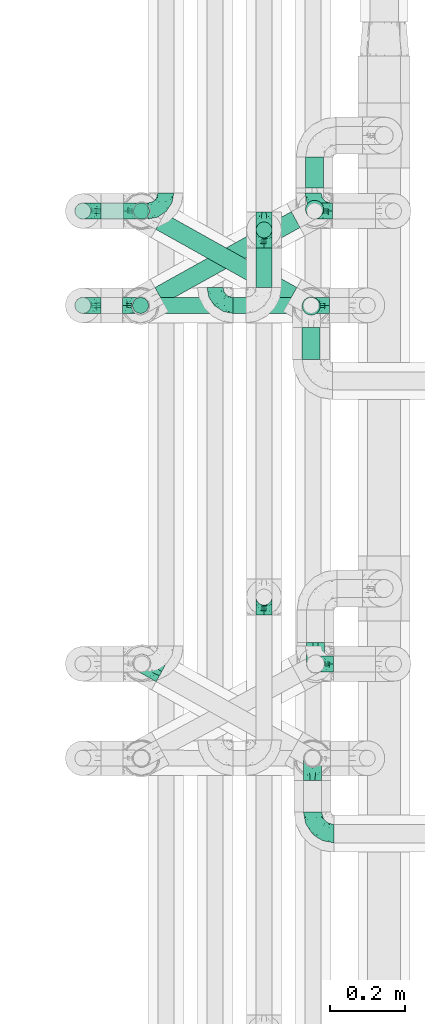
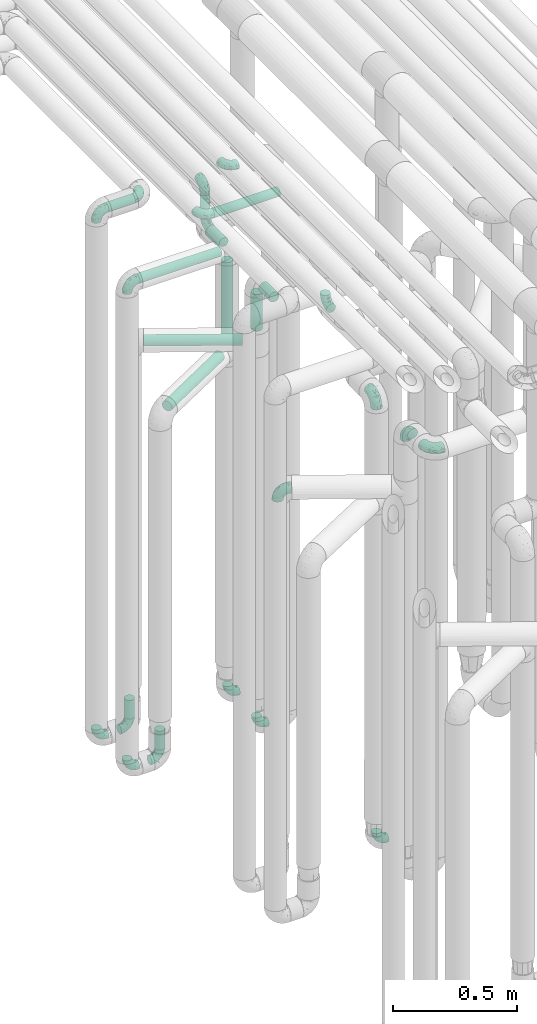
# One storey, part 600 of 824: 19 flow fittings, 13 flow segments.
"""IFC2X3 building model written with IfcOpenShell, lengths in millimetres."""

from ifc_helpers import new_model, entity, si_unit, converted_unit, derived_unit, direction, frame, origin, origin_2d_with_axis, place, context, subcontext, project, spatial, circle, extrude, faceted_brep, source, transform, mapped, material, type_object, type_shapes, element, save


model = new_model("IFC2X3")

# Units and contexts
model_context = context("Model", 3, precision=0.01, world=origin(), true_north=direction((6.12303176911189e-17, 1.0)))
body_context = subcontext(model_context, "Body", "Model", "MODEL_VIEW")
ifc_project = project(units=[si_unit("LENGTHUNIT", "METRE", prefix="MILLI"), si_unit("AREAUNIT", "SQUARE_METRE"), si_unit("VOLUMEUNIT", "CUBIC_METRE"), converted_unit("PLANEANGLEUNIT", "DEGREE", entity("IfcRatioMeasure", 0.0174532925199433), si_unit("PLANEANGLEUNIT", "RADIAN"), dimensions=[0, 0, 0, 0, 0, 0, 0]), si_unit("MASSUNIT", "GRAM", prefix="KILO"), derived_unit("MASSDENSITYUNIT", [(si_unit("MASSUNIT", "GRAM", prefix="KILO"), 1), (si_unit("LENGTHUNIT", "METRE"), -3)]), derived_unit("MOMENTOFINERTIAUNIT", [(si_unit("LENGTHUNIT", "METRE"), 4)]), si_unit("TIMEUNIT", "SECOND"), si_unit("FREQUENCYUNIT", "HERTZ"), si_unit("THERMODYNAMICTEMPERATUREUNIT", "DEGREE_CELSIUS"), derived_unit("THERMALTRANSMITTANCEUNIT", [(si_unit("MASSUNIT", "GRAM", prefix="KILO"), 1), (si_unit("THERMODYNAMICTEMPERATUREUNIT", "KELVIN"), -1), (si_unit("TIMEUNIT", "SECOND"), -3)]), derived_unit("VOLUMETRICFLOWRATEUNIT", [(si_unit("LENGTHUNIT", "METRE"), 3), (si_unit("TIMEUNIT", "SECOND"), -1)]), derived_unit("MASSFLOWRATEUNIT", [(si_unit("MASSUNIT", "GRAM", prefix="KILO"), 1), (si_unit("TIMEUNIT", "SECOND"), -1)]), derived_unit("ROTATIONALFREQUENCYUNIT", [(si_unit("TIMEUNIT", "SECOND"), -1)]), si_unit("ELECTRICCURRENTUNIT", "AMPERE"), si_unit("ELECTRICVOLTAGEUNIT", "VOLT"), si_unit("POWERUNIT", "WATT"), si_unit("FORCEUNIT", "NEWTON", prefix="KILO"), si_unit("ILLUMINANCEUNIT", "LUX"), si_unit("LUMINOUSFLUXUNIT", "LUMEN"), si_unit("LUMINOUSINTENSITYUNIT", "CANDELA"), derived_unit("USERDEFINED", [(si_unit("MASSUNIT", "GRAM", prefix="KILO"), -1), (si_unit("LENGTHUNIT", "METRE"), -2), (si_unit("TIMEUNIT", "SECOND"), 3), (si_unit("LUMINOUSFLUXUNIT", "LUMEN"), 1)]), derived_unit("LINEARVELOCITYUNIT", [(si_unit("LENGTHUNIT", "METRE"), 1), (si_unit("TIMEUNIT", "SECOND"), -1)]), si_unit("PRESSUREUNIT", "PASCAL"), derived_unit("USERDEFINED", [(si_unit("LENGTHUNIT", "METRE"), -2), (si_unit("MASSUNIT", "GRAM", prefix="KILO"), 1), (si_unit("TIMEUNIT", "SECOND"), -2)]), derived_unit("LINEARFORCEUNIT", [(si_unit("MASSUNIT", "GRAM", prefix="KILO"), 1), (si_unit("LENGTHUNIT", "METRE"), 1), (si_unit("TIMEUNIT", "SECOND"), -2), (si_unit("LENGTHUNIT", "METRE"), -1)]), derived_unit("PLANARFORCEUNIT", [(si_unit("MASSUNIT", "GRAM", prefix="KILO"), 1), (si_unit("LENGTHUNIT", "METRE"), 1), (si_unit("TIMEUNIT", "SECOND"), -2), (si_unit("LENGTHUNIT", "METRE"), -2)])], contexts=[model_context])

# Site, building, storey
site_placement = place(None, origin())
site = spatial("IfcSite", under=ifc_project, at=site_placement, CompositionType="ELEMENT")
building_placement = place(site_placement, origin())
building = spatial("IfcBuilding", under=site, at=building_placement, CompositionType="ELEMENT")
storey_placement = place(building_placement, frame((0.0, 0.0, 28200.0)))
storey = spatial("IfcBuildingStorey", under=building, at=storey_placement, CompositionType="ELEMENT", Elevation=28200.0)

# Flow segments
pipe_segment_type = type_object("IfcPipeSegmentType", PredefinedType="NOTDEFINED")
flow_segment_1_placement = place(storey_placement, frame((35168.03, 12983.46, 2977.25)))
element("IfcFlowSegment", 1, at=flow_segment_1_placement, inside=storey, type_object=pipe_segment_type, context=body_context, shape_type="SweptSolid", body=[
    extrude(circle(Radius=21.15, at=origin_2d_with_axis()), frame((0.0, 22.75, 22.75), z_axis=(1.0, 0.0, 0.0), x_axis=(0.0, 1.0, 0.0)), (0.0, 0.0, 1.0), 124.000000000015),
])
for number, where in (
    (2, (35252.6, 12983.46, 448.0)),
    (3, (35250.16, 12733.46, 448.0)),
):
    element("IfcFlowSegment", number, at=place(storey_placement, frame(where)), inside=storey, type_object=pipe_segment_type, context=body_context, shape_type="SweptSolid", body=[
        extrude(circle(Radius=21.15, at=origin_2d_with_axis()), frame((22.75, 22.75, 0.0), z_axis=(0.0, 0.0, 1.0), x_axis=(-1.0, 0.0, 0.0)), (0.0, 0.0, 1.0), 92.0000000000094),
    ])
flow_segment_2_placement = place(storey_placement, frame((35577.35, 12933.43, 2847.61)))
element("IfcFlowSegment", 4, at=flow_segment_2_placement, inside=storey, type_object=pipe_segment_type, context=body_context, shape_type="SweptSolid", body=[
    extrude(circle(Radius=21.15, at=origin_2d_with_axis()), frame((22.75, 22.75, 0.0)), (0.0, 0.0, 1.0), 104.39114387437),
])
flow_segment_3_placement = place(storey_placement, frame((35577.35, 12804.17, 2776.86)))
element("IfcFlowSegment", 5, at=flow_segment_3_placement, inside=storey, type_object=pipe_segment_type, context=body_context, shape_type="SweptSolid", body=[
    extrude(circle(Radius=21.15, at=origin_2d_with_axis()), frame((22.75, 0.0, 22.75), z_axis=(0.0, 1.0, 0.0), x_axis=(-1.0, 0.0, 0.0)), (0.0, 0.0, 1.0), 104.000000000015),
])
flow_segment_4_placement = place(storey_placement, frame((35168.03, 12733.43, 2776.86)))
element("IfcFlowSegment", 6, at=flow_segment_4_placement, inside=storey, type_object=pipe_segment_type, context=body_context, shape_type="SweptSolid", body=[
    extrude(circle(Radius=21.15, at=origin_2d_with_axis()), frame((0.0, 22.77, 22.75), z_axis=(0.999999997789185, -6.64953413086212e-05, 0.0), x_axis=(-6.64953413086212e-05, -0.999999997789185, 0.0)), (0.0, 0.0, 1.0), 384.054259178842),
])
flow_segment_5_placement = place(storey_placement, frame((35518.03, 12733.42, 2977.25)))
element("IfcFlowSegment", 7, at=flow_segment_5_placement, inside=storey, type_object=pipe_segment_type, context=body_context, shape_type="SweptSolid", body=[
    extrude(circle(Radius=21.15, at=origin_2d_with_axis()), frame((0.0, 22.75, 22.75), z_axis=(1.0, 0.0, 0.0), x_axis=(0.0, -1.0, 0.0)), (0.0, 0.0, 1.0), 307.750000000012),
])
flow_segment_6_placement = place(storey_placement, frame((35708.54, 12985.08, 2157.0)))
element("IfcFlowSegment", 8, at=flow_segment_6_placement, inside=storey, type_object=pipe_segment_type, context=body_context, shape_type="SweptSolid", body=[
    extrude(circle(Radius=24.0, at=origin_2d_with_axis()), frame((25.6, 25.6, 0.0), z_axis=(0.0, 0.0, 1.0), x_axis=(-1.0, 0.0, 0.0)), (0.0, 0.0, 1.0), 385.999999999986),
])
flow_segment_7_placement = place(storey_placement, frame((35699.44, 12728.87, 2362.0)))
element("IfcFlowSegment", 9, at=flow_segment_7_placement, inside=storey, type_object=pipe_segment_type, context=body_context, shape_type="SweptSolid", body=[
    extrude(circle(Radius=24.0, at=origin_2d_with_axis()), frame((25.6, 25.6, 0.0), z_axis=(0.0, 0.0, 1.0), x_axis=(-1.0, 0.0, 0.0)), (0.0, 0.0, 1.0), 180.999999999998),
])
flow_segment_8_placement = place(storey_placement, frame((35311.78, 12760.12, 2279.4)))
element("IfcFlowSegment", 10, at=flow_segment_8_placement, inside=storey, type_object=pipe_segment_type, context=body_context, shape_type="SweptSolid", body=[
    extrude(circle(Radius=24.0, at=origin_2d_with_axis()), frame((13.31, 218.58, 25.6), z_axis=(0.872709832917215, -0.488239231862421, 0.0), x_axis=(-0.488239231862421, -0.872709832917215, 0.0)), (0.0, 0.0, 1.0), 401.518720143664),
])
flow_segment_9_placement = place(storey_placement, frame((35309.45, 12759.99, 2074.4)))
element("IfcFlowSegment", 11, at=flow_segment_9_placement, inside=storey, type_object=pipe_segment_type, context=body_context, shape_type="SweptSolid", body=[
    extrude(circle(Radius=24.0, at=origin_2d_with_axis()), frame((13.26, 22.57, 25.6), z_axis=(0.873900740639491, 0.486104408033654, 0.0), x_axis=(0.486104408033654, -0.873900740639491, 0.0)), (0.0, 0.0, 1.0), 413.435297220392),
])
flow_segment_10_placement = place(storey_placement, frame((35708.65, 13067.49, 2574.4)))
element("IfcFlowSegment", 12, at=flow_segment_10_placement, inside=storey, type_object=pipe_segment_type, context=body_context, shape_type="SweptSolid", body=[
    extrude(circle(Radius=24.0, at=origin_2d_with_axis()), frame((25.6, 0.0, 25.6), z_axis=(0.0, 1.0, 0.0), x_axis=(1.0, 0.0, 0.0)), (0.0, 0.0, 1.0), 81.5902938725285),
])
flow_segment_11_placement = place(storey_placement, frame((35699.44, 12613.08, 2574.4)))
element("IfcFlowSegment", 13, at=flow_segment_11_placement, inside=storey, type_object=pipe_segment_type, context=body_context, shape_type="SweptSolid", body=[
    extrude(circle(Radius=24.0, at=origin_2d_with_axis()), frame((25.6, 0.0, 25.6), z_axis=(0.0, 1.0, 0.0), x_axis=(-1.0, 0.0, 0.0)), (0.0, 0.0, 1.0), 84.3822522691478),
])

# Flow fittings
ifc_material = material()
pipe_fitting_type_1 = type_object("IfcPipeFittingType", PredefinedType="NOTDEFINED", material=ifc_material)
shared_shape_1 = source(origin(), body_context, "Body", "Brep", [
    faceted_brep([(-57.0, 12.07, -20.91), (-57.0, 6.25, -23.33), (-57.0, 0.0, -24.15), (-57.0, -6.25, -23.33), (-57.0, -12.08, -20.91), (-57.0, -17.08, -17.08), (-57.0, -20.91, -12.08), (-57.0, -23.33, -6.25), (-57.0, -24.15, 0.0), (-57.0, -23.33, 6.25), (-57.0, -20.91, 12.07), (-57.0, -17.08, 17.08), (-57.0, -12.08, 20.91), (-57.0, -6.25, 23.33), (-57.0, 0.0, 24.15), (-57.0, 6.25, 23.33), (-57.0, 12.07, 20.91), (-57.0, 17.08, 17.08), (-57.0, 20.91, 12.07), (-57.0, 23.33, 6.25), (-57.0, 24.15, 0.0), (-57.0, 23.33, -6.25), (-57.0, 20.91, -12.08), (-57.0, 17.08, -17.08), (0.0, 57.0, -24.15), (-6.25, 57.0, -23.33), (-12.07, 57.0, -20.91), (-17.08, 57.0, -17.08), (-20.91, 57.0, -12.08), (-23.33, 57.0, -6.25), (-24.15, 57.0, 0.0), (-23.33, 57.0, 6.25), (-20.91, 57.0, 12.07), (-17.08, 57.0, 17.08), (-12.07, 57.0, 20.91), (-6.25, 57.0, 23.33), (0.0, 57.0, 24.15), (6.25, 57.0, 23.33), (12.08, 57.0, 20.91), (17.08, 57.0, 17.08), (20.91, 57.0, 12.07), (23.33, 57.0, 6.25), (24.15, 57.0, 0.0), (23.33, 57.0, -6.25), (20.91, 57.0, -12.08), (17.08, 57.0, -17.08), (12.08, 57.0, -20.91), (6.25, 57.0, -23.33), (14.9, 21.14, 6.17), (13.61, 24.64, 12.48), (6.23, 8.95, 8.98), (-41.47, -21.06, 0.0), (-41.92, -18.38, 13.72), (-24.64, -13.61, 12.48), (-37.37, -13.24, 18.15), (-6.8, -4.93, 8.18), (-21.76, -15.19, 6.22), (-12.78, -9.18, 0.0), (-37.73, -20.51, 7.75), (-7.38, 7.38, 20.24), (-23.37, -4.26, 20.42), (-11.9, -3.19, 15.86), (-42.14, -8.7, 21.82), (13.24, 37.37, 18.15), (9.33, 23.53, 16.85), (4.26, 23.37, 20.42), (2.77, 10.92, 15.55), (-29.46, 0.91, 23.52), (-44.13, 20.56, 15.69), (-39.25, 26.33, 10.88), (-49.02, 22.92, 9.96), (-34.58, 23.87, 17.15), (-15.8, 6.8, 22.81), (-8.67, 20.47, 23.88), (-18.12, 12.9, 24.08), (-48.29, 14.92, 19.65), (-44.06, -2.85, 23.78), (-9.23, 48.95, 22.58), (-3.78, 42.74, 24.07), (-40.34, 4.26, 24.09), (-44.02, 26.14, 5.46), (-44.04, 9.88, 22.74), (-4.95, 16.87, 22.52), (-2.75, 1.43, 12.5), (-25.48, 40.98, 10.71), (20.51, 37.73, 7.75), (18.38, 41.92, 13.72), (8.7, 42.14, 21.82), (-25.95, -17.97, 0.0), (2.85, 44.06, 23.78), (21.06, 41.47, 0.0), (17.97, 25.95, 0.0), (-24.04, -9.27, 17.13), (-33.26, 33.26, 5.86), (-28.55, 40.57, 0.0), (-40.57, 28.55, 0.0), (-25.29, 47.19, 4.06), (-27.01, 31.1, 16.77), (-15.7, 43.95, 19.9), (-20.27, 45.22, 15.61), (-30.53, 31.98, 12.64), (-11.28, 38.33, 22.92), (-9.97, 27.88, 24.09), (-20.15, 30.26, 21.25), (-31.25, 11.75, 23.64), (-28.75, 7.23, 24.15), (-29.53, 18.06, 22.27), (-28.44, 24.21, 20.02), (-37.55, 17.7, 20.26), (-15.88, 29.25, 22.99), (-20.82, 20.82, 23.44), (-0.91, 29.46, 23.52), (-13.5, -7.67, 12.04), (1.49, 1.56, 5.16), (8.86, 10.35, 4.59), (0.38, -0.38, 0.0), (9.18, 12.78, 0.0), (-37.37, -13.24, -18.15), (8.86, 10.35, -4.59), (-45.22, 20.27, -15.61), (-43.95, 15.7, -19.9), (-38.33, 11.28, -22.92), (-48.95, 9.23, -22.58), (-47.19, 25.29, -4.06), (-33.26, 33.26, -5.86), (18.38, 41.92, -13.72), (-30.26, 20.15, -21.25), (2.85, 44.06, -23.78), (-4.26, 40.34, -24.09), (-40.98, 25.48, -10.71), (-41.92, -18.38, -13.72), (9.25, 23.5, -16.92), (4.26, 23.37, -20.42), (13.24, 37.37, -18.15), (-37.73, -20.51, -7.75), (-11.75, 31.25, -23.64), (-7.23, 28.75, -24.15), (-12.9, 18.12, -24.08), (8.7, 42.14, -21.82), (-44.06, -2.85, -23.78), (-6.8, 15.8, -22.81), (-20.47, 8.67, -23.88), (-24.64, -13.61, -12.48), (-42.74, 3.78, -24.07), (-18.06, 29.53, -22.27), (-24.21, 28.44, -20.02), (-27.88, 9.97, -24.09), (-31.1, 27.01, -16.77), (-26.14, 44.02, -5.46), (14.9, 21.14, -6.17), (20.51, 37.73, -7.75), (-9.88, 44.04, -22.74), (-20.56, 44.13, -15.69), (-21.76, -15.19, -6.22), (-13.5, -7.67, -12.04), (-24.14, -9.76, -16.74), (-11.9, -3.19, -15.86), (-14.92, 48.29, -19.65), (-23.37, -4.26, -20.42), (-0.91, 29.46, -23.52), (-26.33, 39.25, -10.88), (-23.87, 34.58, -17.15), (-42.14, -8.7, -21.82), (-22.92, 49.02, -9.96), (13.61, 24.64, -12.48), (-31.98, 30.53, -12.64), (-16.87, 4.95, -22.52), (-17.7, 37.55, -20.26), (-29.25, 15.88, -22.99), (-20.82, 20.82, -23.44), (-29.46, 0.91, -23.52), (-7.38, 7.38, -20.24), (2.77, 10.92, -15.55), (6.23, 8.95, -8.98), (-6.8, -4.93, -8.18), (-2.81, 1.41, -12.54), (1.49, 1.56, -5.16)], [[[0, 1, 2, 3, 4, 5, 6, 7, 8, 9, 10, 11, 12, 13, 14, 15, 16, 17, 18, 19, 20, 21, 22, 23]], [[24, 25, 26, 27, 28, 29, 30, 31, 32, 33, 34, 35, 36, 37, 38, 39, 40, 41, 42, 43, 44, 45, 46, 47]], [[48, 49, 50]], [[9, 8, 51]], [[52, 53, 54]], [[55, 56, 57]], [[10, 58, 52]], [[9, 58, 10]], [[59, 60, 61]], [[54, 12, 11]], [[54, 62, 12]], [[63, 39, 38]], [[64, 65, 66]], [[62, 60, 67]], [[68, 69, 70]], [[71, 69, 68]], [[72, 73, 74]], [[16, 75, 17]], [[13, 76, 14]], [[35, 77, 78]], [[14, 79, 15]], [[17, 68, 18]], [[14, 76, 79]], [[20, 19, 80]], [[70, 19, 18]], [[81, 15, 79]], [[15, 81, 16]], [[73, 72, 82]], [[66, 83, 50]], [[32, 31, 84]], [[85, 86, 49]], [[63, 87, 65]], [[56, 58, 88]], [[36, 89, 37]], [[85, 41, 40]], [[36, 35, 78]], [[90, 41, 85]], [[40, 39, 86]], [[12, 62, 13]], [[86, 85, 40]], [[48, 85, 49]], [[85, 91, 90]], [[87, 38, 37]], [[92, 60, 54]], [[80, 69, 93]], [[93, 94, 95]], [[10, 52, 11]], [[94, 96, 30]], [[97, 98, 99]], [[80, 93, 95]], [[100, 97, 84]], [[99, 98, 33]], [[101, 102, 78]], [[103, 101, 98]], [[96, 31, 30]], [[77, 98, 101]], [[77, 35, 34]], [[34, 33, 98]], [[9, 51, 58]], [[87, 63, 38]], [[104, 105, 74]], [[106, 103, 107]], [[106, 81, 104]], [[75, 68, 17]], [[108, 107, 71]], [[33, 32, 99]], [[109, 103, 110]], [[101, 109, 102]], [[89, 78, 111]], [[53, 52, 58]], [[54, 11, 52]], [[60, 62, 54]], [[88, 58, 51]], [[76, 62, 67]], [[53, 112, 92]], [[60, 59, 72]], [[39, 63, 86]], [[49, 86, 63]], [[89, 87, 37]], [[42, 41, 90]], [[111, 82, 65]], [[111, 65, 87]], [[65, 59, 66]], [[104, 81, 79]], [[75, 81, 108]], [[32, 84, 99]], [[97, 99, 84]], [[98, 97, 103]], [[106, 107, 108]], [[74, 102, 110]], [[111, 78, 102]], [[74, 110, 104]], [[74, 67, 72]], [[61, 92, 112]], [[66, 59, 61]], [[56, 53, 58]], [[66, 50, 49]], [[61, 112, 83]], [[66, 49, 64]], [[78, 89, 36]], [[87, 89, 111]], [[62, 76, 13]], [[79, 76, 67]], [[100, 93, 69]], [[96, 93, 84]], [[55, 113, 50]], [[113, 114, 50]], [[104, 79, 105]], [[106, 104, 110]], [[20, 80, 95]], [[85, 48, 91]], [[115, 114, 113]], [[116, 91, 48]], [[70, 80, 19]], [[93, 96, 94]], [[84, 31, 96]], [[103, 106, 110]], [[81, 106, 108]], [[103, 97, 107]], [[71, 107, 97]], [[71, 97, 100]], [[108, 71, 68]], [[79, 67, 105]], [[67, 74, 105]], [[115, 113, 57]], [[112, 56, 55]], [[56, 88, 57]], [[60, 72, 67]], [[82, 72, 59]], [[65, 82, 59]], [[82, 111, 73]], [[111, 102, 73]], [[102, 74, 73]], [[81, 75, 16]], [[68, 75, 108]], [[68, 70, 18]], [[80, 70, 69]], [[98, 77, 34]], [[78, 77, 101]], [[93, 100, 84]], [[71, 100, 69]], [[102, 109, 110]], [[101, 103, 109]], [[53, 92, 54]], [[61, 60, 92]], [[56, 112, 53]], [[83, 112, 55]], [[50, 83, 55]], [[61, 83, 66]], [[49, 63, 64]], [[65, 64, 63]], [[57, 113, 55]], [[114, 115, 116]], [[116, 48, 114]], [[48, 50, 114]], [[117, 5, 4]], [[116, 115, 118]], [[119, 120, 23]], [[121, 122, 120]], [[95, 123, 20]], [[0, 23, 120]], [[124, 95, 94]], [[125, 45, 44]], [[121, 120, 126]], [[24, 127, 128]], [[22, 21, 129]], [[0, 122, 1]], [[5, 117, 130]], [[131, 132, 133]], [[134, 88, 51]], [[135, 136, 137]], [[6, 5, 130]], [[46, 138, 47]], [[139, 3, 2]], [[140, 141, 137]], [[6, 134, 7]], [[134, 130, 142]], [[143, 2, 1]], [[144, 126, 145]], [[121, 146, 143]], [[147, 120, 119]], [[94, 148, 124]], [[149, 150, 91]], [[30, 29, 148]], [[151, 25, 128]], [[27, 152, 28]], [[134, 153, 88]], [[154, 155, 156]], [[27, 26, 157]], [[151, 26, 25]], [[155, 158, 156]], [[24, 47, 127]], [[1, 122, 143]], [[138, 132, 159]], [[160, 152, 161]], [[24, 128, 25]], [[46, 133, 138]], [[162, 117, 4]], [[148, 160, 124]], [[152, 160, 163]], [[154, 142, 155]], [[45, 125, 133]], [[133, 46, 45]], [[125, 164, 133]], [[51, 7, 134]], [[42, 90, 43]], [[165, 147, 129]], [[153, 134, 142]], [[43, 150, 44]], [[162, 4, 3]], [[141, 140, 166]], [[117, 162, 158]], [[163, 29, 28]], [[43, 90, 150]], [[123, 21, 20]], [[144, 151, 135]], [[157, 152, 27]], [[167, 145, 161]], [[23, 22, 119]], [[168, 126, 169]], [[121, 168, 146]], [[139, 143, 170]], [[142, 130, 117]], [[8, 7, 51]], [[134, 6, 130]], [[139, 162, 3]], [[170, 166, 158]], [[170, 158, 162]], [[158, 171, 156]], [[44, 150, 125]], [[91, 150, 90]], [[164, 125, 150]], [[132, 138, 133]], [[127, 138, 159]], [[131, 164, 172]], [[132, 171, 140]], [[135, 151, 128]], [[157, 151, 167]], [[22, 129, 119]], [[147, 119, 129]], [[120, 147, 126]], [[144, 145, 167]], [[137, 146, 169]], [[170, 143, 146]], [[137, 169, 135]], [[137, 159, 140]], [[171, 172, 156]], [[173, 174, 175]], [[156, 175, 154]], [[174, 57, 153]], [[132, 172, 171]], [[172, 164, 173]], [[143, 139, 2]], [[162, 139, 170]], [[138, 127, 47]], [[128, 127, 159]], [[165, 124, 160]], [[123, 124, 129]], [[149, 173, 164]], [[176, 174, 173]], [[135, 128, 136]], [[144, 135, 169]], [[150, 149, 164]], [[176, 118, 115]], [[149, 91, 116]], [[30, 148, 94]], [[163, 148, 29]], [[124, 123, 95]], [[129, 21, 123]], [[126, 144, 169]], [[151, 144, 167]], [[126, 147, 145]], [[161, 145, 147]], [[161, 147, 165]], [[167, 161, 152]], [[128, 159, 136]], [[159, 137, 136]], [[154, 153, 142]], [[132, 140, 159]], [[174, 176, 57]], [[57, 88, 153]], [[166, 140, 171]], [[158, 166, 171]], [[166, 170, 141]], [[170, 146, 141]], [[146, 137, 141]], [[151, 157, 26]], [[152, 157, 167]], [[152, 163, 28]], [[148, 163, 160]], [[120, 122, 0]], [[143, 122, 121]], [[124, 165, 129]], [[161, 165, 160]], [[146, 168, 169]], [[121, 126, 168]], [[142, 117, 155]], [[158, 155, 117]], [[175, 156, 172]], [[153, 154, 174]], [[173, 175, 172]], [[174, 154, 175]], [[164, 131, 133]], [[172, 132, 131]], [[176, 173, 118]], [[57, 176, 115]], [[173, 149, 118]], [[149, 116, 118]]]),
])
type_shapes(pipe_fitting_type_1, [shared_shape_1])
for number, where, z_axis, x_axis in (
    (14, (35736.85, 11805.67, 2600.0), (-1.0, 0.0, 0.0), (0.0, 0.0, 1.0)),
    (15, (35728.78, 11554.46, 2600.0), (1.0, 0.0, 0.0), (0.0, 0.0, 1.0)),
    (16, (35728.78, 11356.08, 2600.0), (0.0, 0.0, 1.0), (0.0, -1.0, 0.0)),
    (17, (35276.24, 11808.13, 2305.0), (-0.488239203591698, -0.872709848733326, 0.0), (-0.872709848733326, 0.488239203591698, 0.0)),
):
    element("IfcFlowFitting", number, at=place(storey_placement, frame(where, z_axis=z_axis, x_axis=x_axis)), inside=storey, type_object=pipe_fitting_type_1, material=ifc_material, context=body_context, shape_type="MappedRepresentation", body=[
        mapped(shared_shape_1, transform((0.0, 0.0, 0.0), scale=1.0)),
    ])
pipe_fitting_type_2 = type_object("IfcPipeFittingType", PredefinedType="NOTDEFINED", material=ifc_material)
shared_shape_2 = source(origin(), body_context, "Body", "Brep", [
    faceted_brep([(-48.0, 10.6, -18.36), (-48.0, 5.49, -20.48), (-48.0, 0.0, -21.2), (-48.0, -5.49, -20.48), (-48.0, -10.6, -18.36), (-48.0, -14.99, -14.99), (-48.0, -18.36, -10.6), (-48.0, -20.48, -5.49), (-48.0, -21.2, 0.0), (-48.0, -20.48, 5.49), (-48.0, -18.36, 10.6), (-48.0, -14.99, 14.99), (-48.0, -10.6, 18.36), (-48.0, -5.49, 20.48), (-48.0, 0.0, 21.2), (-48.0, 5.49, 20.48), (-48.0, 10.6, 18.36), (-48.0, 14.99, 14.99), (-48.0, 18.36, 10.6), (-48.0, 20.48, 5.49), (-48.0, 21.2, 0.0), (-48.0, 20.48, -5.49), (-48.0, 18.36, -10.6), (-48.0, 14.99, -14.99), (0.0, 48.0, -21.2), (-5.49, 48.0, -20.48), (-10.6, 48.0, -18.36), (-14.99, 48.0, -14.99), (-18.36, 48.0, -10.6), (-20.48, 48.0, -5.49), (-21.2, 48.0, 0.0), (-20.48, 48.0, 5.49), (-18.36, 48.0, 10.6), (-14.99, 48.0, 14.99), (-10.6, 48.0, 18.36), (-5.49, 48.0, 20.48), (0.0, 48.0, 21.2), (5.49, 48.0, 20.48), (10.6, 48.0, 18.36), (14.99, 48.0, 14.99), (18.36, 48.0, 10.6), (20.48, 48.0, 5.49), (21.2, 48.0, 0.0), (20.48, 48.0, -5.49), (18.36, 48.0, -10.6), (14.99, 48.0, -14.99), (10.6, 48.0, -18.36), (5.49, 48.0, -20.48), (-35.25, -16.22, 12.01), (-34.76, -18.57, 0.0), (-20.87, -12.37, 10.9), (-31.49, -11.78, 15.9), (-37.0, -2.58, 20.86), (-33.89, 3.62, 21.15), (-31.81, -18.14, 6.76), (-5.78, 5.78, 17.67), (-19.42, -4.1, 17.86), (-9.6, -3.39, 13.73), (-35.44, -7.73, 19.13), (11.78, 31.49, 15.9), (-5.93, -5.46, 6.95), (-18.45, -13.78, 5.46), (-10.29, -8.43, 0.0), (-24.6, 0.55, 20.62), (-37.28, 17.94, 13.81), (-33.38, 22.85, 9.59), (-41.46, 20.06, 8.75), (-29.51, 20.45, 15.16), (-15.04, 10.79, 21.13), (-7.08, 16.98, 20.93), (-8.39, 23.51, 21.15), (-40.86, 13.03, 17.26), (-8.05, 41.26, 19.83), (-3.21, 35.97, 21.14), (8.53, 19.66, 14.74), (4.1, 19.42, 17.86), (-37.72, 22.66, 4.78), (-37.07, 8.58, 19.98), (-13.0, 5.43, 19.97), (-3.78, 13.93, 19.7), (3.02, 8.69, 13.43), (-2.27, -0.05, 10.65), (6.22, 6.99, 7.09), (-22.25, 34.6, 9.45), (18.14, 31.81, 6.76), (16.22, 35.25, 12.01), (12.37, 20.87, 10.9), (7.73, 35.44, 19.13), (-21.52, -15.93, 0.0), (2.58, 37.0, 20.86), (18.57, 34.76, 0.0), (13.78, 18.45, 5.46), (15.93, 21.52, 0.0), (-20.03, -8.54, 14.9), (-28.6, 28.6, 5.16), (-24.79, 34.6, 0.0), (-34.6, 24.79, 0.0), (-22.81, 37.41, 4.68), (-23.36, 26.33, 14.79), (-13.68, 37.05, 17.49), (-17.72, 38.12, 13.73), (-26.25, 27.3, 11.24), (-9.71, 32.34, 20.14), (-17.26, 25.6, 18.71), (-26.33, 9.99, 20.77), (-24.06, 6.05, 21.2), (-25.02, 15.46, 19.56), (-24.3, 20.72, 17.57), (-31.95, 15.23, 17.8), (-13.53, 24.7, 20.21), (-17.6, 17.6, 20.6), (-0.55, 24.6, 20.62), (-11.41, -7.48, 10.43), (0.93, -0.93, 0.0), (8.43, 10.29, 0.0), (-11.41, -7.48, -10.43), (-20.1, -8.84, -14.66), (-9.6, -3.39, -13.73), (7.73, 35.44, -19.13), (4.1, 19.42, -17.86), (-0.55, 24.6, -20.62), (-38.12, 17.72, -13.73), (-37.05, 13.68, -17.49), (-32.34, 9.71, -20.14), (-41.26, 8.05, -19.83), (-37.41, 22.81, -4.68), (-23.51, 8.39, -21.15), (-35.97, 3.21, -21.14), (-28.6, 28.6, -5.16), (-31.81, -18.14, -6.76), (-18.45, -13.78, -5.46), (-25.6, 17.26, -18.71), (-19.42, -4.1, -17.86), (-17.94, 37.28, -13.81), (-22.85, 33.38, -9.59), (-20.06, 41.46, -8.75), (-31.49, -11.78, -15.9), (-35.25, -16.22, -12.01), (8.53, 19.66, -14.74), (11.78, 31.49, -15.9), (-9.99, 26.33, -20.77), (-6.05, 24.06, -21.2), (-10.79, 15.04, -21.13), (-37.0, -2.58, -20.86), (-16.98, 7.08, -20.93), (-5.43, 13.0, -19.97), (-13.93, 3.78, -19.7), (-20.87, -12.37, -10.9), (-26.33, 23.36, -14.79), (-22.66, 37.72, -4.78), (13.78, 18.45, -5.46), (18.14, 31.81, -6.76), (-15.46, 25.02, -19.56), (-20.72, 24.3, -17.57), (16.22, 35.25, -12.01), (-13.03, 40.86, -17.26), (-8.58, 37.07, -19.98), (2.58, 37.0, -20.86), (-3.62, 33.89, -21.15), (-34.6, 22.25, -9.45), (6.22, 6.99, -7.09), (-20.45, 29.51, -15.16), (-35.44, -7.73, -19.13), (12.37, 20.87, -10.9), (-27.3, 26.25, -11.24), (-15.23, 31.95, -17.8), (-24.7, 13.53, -20.21), (-24.6, 0.55, -20.62), (-5.78, 5.78, -17.67), (-17.6, 17.6, -20.6), (3.02, 8.69, -13.43), (-5.93, -5.46, -6.95), (-2.27, -0.05, -10.65)], [[[0, 1, 2, 3, 4, 5, 6, 7, 8, 9, 10, 11, 12, 13, 14, 15, 16, 17, 18, 19, 20, 21, 22, 23]], [[24, 25, 26, 27, 28, 29, 30, 31, 32, 33, 34, 35, 36, 37, 38, 39, 40, 41, 42, 43, 44, 45, 46, 47]], [[10, 48, 11]], [[9, 8, 49]], [[48, 50, 51]], [[14, 52, 53]], [[10, 54, 48]], [[9, 54, 10]], [[55, 56, 57]], [[51, 12, 11]], [[51, 58, 12]], [[59, 39, 38]], [[60, 61, 62]], [[58, 56, 63]], [[64, 65, 66]], [[67, 65, 64]], [[68, 69, 70]], [[16, 71, 17]], [[13, 52, 14]], [[35, 72, 73]], [[14, 53, 15]], [[17, 64, 18]], [[74, 59, 75]], [[20, 19, 76]], [[66, 19, 18]], [[77, 15, 53]], [[15, 77, 16]], [[69, 78, 79]], [[80, 81, 82]], [[32, 31, 83]], [[84, 85, 86]], [[59, 87, 75]], [[61, 54, 88]], [[36, 89, 37]], [[84, 41, 40]], [[36, 35, 73]], [[90, 41, 84]], [[40, 39, 85]], [[12, 58, 13]], [[85, 84, 40]], [[91, 84, 86]], [[84, 92, 90]], [[87, 38, 37]], [[93, 56, 51]], [[65, 94, 76]], [[94, 95, 96]], [[84, 91, 92]], [[95, 97, 30]], [[98, 99, 100]], [[76, 94, 96]], [[101, 98, 83]], [[100, 99, 33]], [[102, 70, 73]], [[103, 102, 99]], [[94, 97, 95]], [[72, 99, 102]], [[72, 35, 34]], [[34, 33, 99]], [[9, 49, 54]], [[87, 59, 38]], [[104, 105, 68]], [[106, 103, 107]], [[106, 77, 104]], [[71, 64, 17]], [[108, 107, 67]], [[33, 32, 100]], [[109, 103, 110]], [[102, 109, 70]], [[89, 73, 111]], [[50, 48, 54]], [[51, 11, 48]], [[56, 58, 51]], [[88, 54, 49]], [[52, 58, 63]], [[50, 112, 93]], [[56, 55, 78]], [[39, 59, 85]], [[86, 85, 59]], [[89, 87, 37]], [[42, 41, 90]], [[111, 79, 75]], [[111, 75, 87]], [[75, 55, 80]], [[104, 77, 53]], [[71, 77, 108]], [[32, 83, 100]], [[98, 100, 83]], [[99, 98, 103]], [[106, 107, 108]], [[68, 70, 110]], [[111, 73, 70]], [[68, 110, 104]], [[68, 63, 78]], [[57, 93, 112]], [[80, 55, 57]], [[61, 50, 54]], [[80, 82, 86]], [[81, 57, 112]], [[74, 86, 59]], [[60, 113, 82]], [[82, 114, 91]], [[101, 94, 65]], [[97, 94, 83]], [[73, 89, 36]], [[87, 89, 111]], [[58, 52, 13]], [[53, 52, 63]], [[104, 53, 105]], [[106, 104, 110]], [[20, 76, 96]], [[76, 19, 66]], [[103, 106, 110]], [[77, 106, 108]], [[103, 98, 107]], [[67, 107, 98]], [[67, 98, 101]], [[108, 67, 64]], [[53, 63, 105]], [[63, 68, 105]], [[83, 31, 97]], [[30, 97, 31]], [[62, 113, 60]], [[112, 61, 60]], [[61, 88, 62]], [[86, 82, 91]], [[56, 78, 63]], [[114, 82, 113]], [[114, 92, 91]], [[79, 78, 55]], [[75, 79, 55]], [[69, 79, 111]], [[70, 69, 111]], [[78, 69, 68]], [[77, 71, 16]], [[64, 71, 108]], [[64, 66, 18]], [[76, 66, 65]], [[99, 72, 34]], [[73, 72, 102]], [[94, 101, 83]], [[67, 101, 65]], [[75, 80, 74]], [[80, 86, 74]], [[70, 109, 110]], [[102, 103, 109]], [[50, 93, 51]], [[57, 56, 93]], [[61, 112, 50]], [[81, 112, 60]], [[82, 81, 60]], [[80, 57, 81]], [[115, 116, 117]], [[118, 119, 120]], [[121, 122, 23]], [[123, 124, 122]], [[96, 125, 20]], [[123, 126, 127]], [[128, 96, 95]], [[129, 130, 88]], [[123, 122, 131]], [[116, 132, 117]], [[133, 134, 135]], [[0, 124, 1]], [[5, 136, 137]], [[138, 119, 139]], [[129, 88, 49]], [[140, 141, 142]], [[6, 5, 137]], [[46, 118, 47]], [[143, 3, 2]], [[144, 145, 146]], [[6, 129, 7]], [[129, 137, 147]], [[127, 2, 1]], [[148, 122, 121]], [[128, 125, 96]], [[134, 128, 149]], [[95, 149, 128]], [[150, 151, 92]], [[30, 29, 149]], [[152, 131, 153]], [[27, 133, 28]], [[154, 45, 44]], [[136, 5, 4]], [[27, 26, 155]], [[156, 26, 25]], [[24, 157, 158]], [[24, 47, 157]], [[22, 21, 159]], [[160, 150, 114]], [[134, 133, 161]], [[142, 144, 126]], [[46, 139, 118]], [[162, 136, 4]], [[156, 25, 158]], [[1, 124, 127]], [[115, 147, 116]], [[45, 154, 139]], [[139, 46, 45]], [[154, 163, 139]], [[162, 4, 3]], [[42, 90, 43]], [[130, 129, 147]], [[49, 7, 129]], [[43, 151, 44]], [[0, 23, 122]], [[24, 158, 25]], [[136, 162, 132]], [[135, 29, 28]], [[43, 90, 151]], [[164, 148, 159]], [[152, 156, 140]], [[155, 133, 27]], [[165, 153, 161]], [[23, 22, 121]], [[123, 131, 166]], [[123, 166, 126]], [[143, 127, 167]], [[147, 137, 136]], [[8, 7, 49]], [[129, 6, 137]], [[143, 162, 3]], [[167, 146, 132]], [[167, 132, 162]], [[132, 168, 117]], [[44, 151, 154]], [[92, 151, 90]], [[163, 154, 151]], [[119, 118, 139]], [[157, 118, 120]], [[138, 139, 163]], [[119, 168, 145]], [[140, 156, 158]], [[155, 156, 165]], [[22, 159, 121]], [[148, 121, 159]], [[122, 148, 131]], [[152, 153, 165]], [[142, 126, 169]], [[167, 127, 126]], [[142, 169, 140]], [[142, 120, 145]], [[168, 170, 117]], [[160, 171, 172]], [[115, 172, 171]], [[171, 62, 130]], [[119, 170, 168]], [[170, 163, 160]], [[150, 163, 151]], [[113, 171, 160]], [[164, 128, 134]], [[125, 128, 159]], [[127, 143, 2]], [[162, 143, 167]], [[118, 157, 47]], [[158, 157, 120]], [[140, 158, 141]], [[152, 140, 169]], [[30, 149, 95]], [[149, 29, 135]], [[131, 152, 169]], [[156, 152, 165]], [[131, 148, 153]], [[161, 153, 148]], [[161, 148, 164]], [[165, 161, 133]], [[158, 120, 141]], [[120, 142, 141]], [[159, 21, 125]], [[20, 125, 21]], [[115, 130, 147]], [[114, 113, 160]], [[62, 171, 113]], [[62, 88, 130]], [[160, 163, 150]], [[150, 92, 114]], [[119, 145, 120]], [[146, 145, 168]], [[132, 146, 168]], [[144, 146, 167]], [[126, 144, 167]], [[145, 144, 142]], [[156, 155, 26]], [[133, 155, 165]], [[133, 135, 28]], [[149, 135, 134]], [[122, 124, 0]], [[127, 124, 123]], [[128, 164, 159]], [[161, 164, 134]], [[163, 170, 138]], [[170, 119, 138]], [[131, 169, 166]], [[126, 166, 169]], [[147, 136, 116]], [[132, 116, 136]], [[172, 115, 117]], [[130, 115, 171]], [[117, 170, 172]], [[160, 172, 170]]]),
])
type_shapes(pipe_fitting_type_2, [shared_shape_2])
flow_fitting_placement = place(storey_placement, frame((35340.03, 13006.2, 3000.0)))
element("IfcFlowFitting", 18, at=flow_fitting_placement, inside=storey, type_object=pipe_fitting_type_2, material=ifc_material, context=body_context, shape_type="MappedRepresentation", body=[
    mapped(shared_shape_2, transform((0.0, 0.0, 0.0), scale=1.0)),
])
for number, where, z_axis, x_axis in (
    (19, (35120.03, 13006.2, 3000.0), (0.0, -1.0, 0.0), (-1.0, 0.0, 0.0)),
    (20, (35120.03, 13006.2, 400.0), (0.0, -1.0, 0.0), (0.0, 0.0, -1.0)),
    (21, (35275.34, 13006.2, 400.0), (0.0, -1.0, 0.0), (1.0, 0.0, 0.0)),
    (22, (35120.03, 12756.2, 400.0), (0.0, -1.0, 0.0), (0.0, 0.0, -1.0)),
    (23, (35272.9, 12756.2, 400.0), (0.0, -1.0, 0.0), (1.0, 0.0, 0.0)),
    (24, (35600.09, 12956.17, 3000.0), (1.0, 0.0, 0.0), (0.0, -1.0, 0.0)),
    (25, (35600.09, 12956.17, 2799.61), (-1.0, 0.0, 0.0), (0.0, 0.0, -1.0)),
    (26, (35120.03, 12756.2, 2799.61), (6.64953412912837e-05, 0.999999997789185, 0.0), (0.0, 0.0, 1.0)),
    (27, (35470.03, 12756.17, 3000.0), (0.0, 0.0, 1.0), (0.0, -1.0, 0.0)),
    (28, (35725.03, 12756.17, 400.0), (0.0, 1.0, 0.0), (-1.0, 0.0, 0.0)),
    (29, (35734.14, 13006.2, 400.0), (0.0, 1.0, 0.0), (-1.0, 0.0, 0.0)),
    (30, (35730.03, 13006.2, 3000.0), (0.0, 0.0, 1.0), (0.0, -1.0, 0.0)),
    (31, (35600.09, 11983.2, 3000.0), (-1.0, 0.0, 0.0), (0.0, 0.0, -1.0)),
    (32, (35736.85, 11806.2, 400.0), (0.0, 0.999999930761682, 0.000372124482818008), (-1.0, 0.0, 0.0)),
):
    element("IfcFlowFitting", number, at=place(storey_placement, frame(where, z_axis=z_axis, x_axis=x_axis)), inside=storey, type_object=pipe_fitting_type_2, material=ifc_material, context=body_context, shape_type="MappedRepresentation", body=[
        mapped(shared_shape_2, transform((0.0, 0.0, 0.0), scale=1.0)),
    ])

save(model, "model.ifc")
